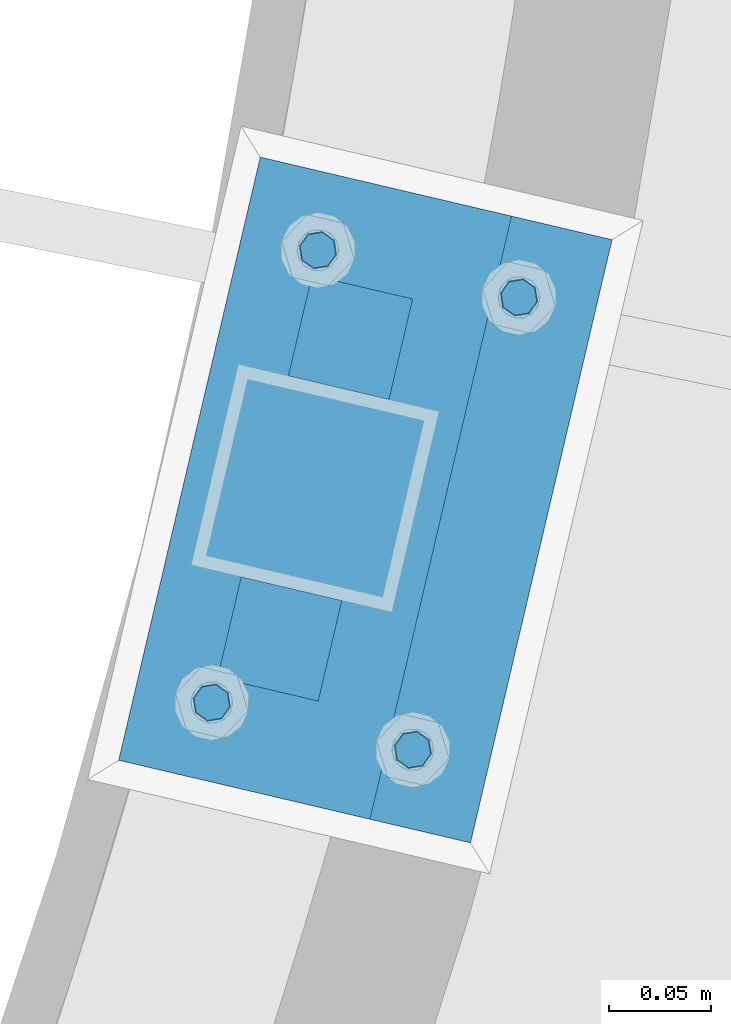
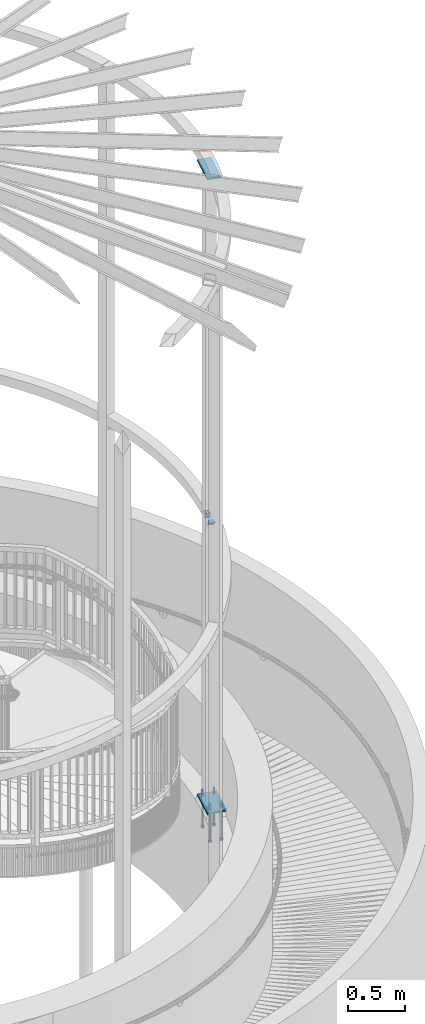
# One storey, part 505 of 975: 9 beams.
"""IFC2X3 building model written with IfcOpenShell, lengths in millimetres."""

from ifc_helpers import new_model, si_unit, frame, origin_with_axes, place, context, subcontext, project, spatial, faceted_brep, material, type_object, element, save


model = new_model("IFC2X3")

# Units and contexts
model_context = context("Model", 3, precision=1e-05, world=origin_with_axes())
body_context = subcontext(model_context, "Body", "Model", "MODEL_VIEW")
ifc_project = project(units=[si_unit("LENGTHUNIT", "METRE", prefix="MILLI"), si_unit("AREAUNIT", "SQUARE_METRE"), si_unit("VOLUMEUNIT", "CUBIC_METRE"), si_unit("MASSUNIT", "GRAM", prefix="KILO"), si_unit("TIMEUNIT", "SECOND"), si_unit("PLANEANGLEUNIT", "RADIAN"), si_unit("SOLIDANGLEUNIT", "STERADIAN"), si_unit("THERMODYNAMICTEMPERATUREUNIT", "DEGREE_CELSIUS"), si_unit("LUMINOUSINTENSITYUNIT", "LUMEN")], contexts=[model_context])

# Site, building, storey
site_placement = place(None, origin_with_axes())
site = spatial("IfcSite", under=ifc_project, at=site_placement, CompositionType="ELEMENT")
building_placement = place(site_placement, origin_with_axes())
building = spatial("IfcBuilding", under=site, at=building_placement, Name="Undefined", CompositionType="ELEMENT")
storey_placement = place(building_placement, origin_with_axes())
storey = spatial("IfcBuildingStorey", under=building, at=storey_placement, Name="Undefined", CompositionType="ELEMENT", Elevation=0.0)

# Beams
ifc_material_1 = material(Name="STEEL/A36")
beam_type_1 = type_object("IfcBeamType", Name="L2X2X1/4", PredefinedType="NOTDEFINED")
for number, where, z_axis, x_axis, name in (
    (1, (37897.6722789189, 2582.8350262257, 4445.0), (-0.228520788077446, -0.973539033329667, 0.0), (0.973539033329667, -0.228520788077446, 0.0), "ANGLE"),
    (2, (37981.954629915, 2719.59351887081, 4445.0), (0.228520788077446, 0.973539033329667, 0.0), (-0.973539033329667, 0.228520788077446, 0.0), "ANGLE"),
):
    element("IfcBeam", number, at=place(storey_placement, frame(where, z_axis=z_axis, x_axis=x_axis)), inside=storey, type_object=beam_type_1, material=ifc_material_1, Name=name, ObjectType="L2X2X1/4", context=body_context, shape_type="Brep", body=[
        faceted_brep([(0.0, 25.3999999999724, -25.4000000000342), (0.0, 25.400000000016, 25.4000000000196), (50.8000000000102, 25.3999999999996, 25.4000000000015), (50.7999999999411, 25.3999999999996, -25.4000000000487), (3.27418092638254e-11, 19.0500000000002, 25.4000000000269), (50.8000000000102, 19.0500000000002, 25.4000000000015), (-2.5465851649642e-11, 19.0500000000002, -19.0500000000211), (50.7999999999483, 19.0500000000002, -19.0500000000429), (-2.5465851649642e-11, -25.3999999999996, -19.0500000000211), (50.7999999999483, -25.3999999999996, -19.0500000000429), (0.0, -25.400000000016, -25.4000000000196), (50.7999999999411, -25.3999999999996, -25.4000000000487)], [[[0, 1, 2, 3]], [[1, 4, 5, 2]], [[4, 6, 7, 5]], [[6, 8, 9, 7]], [[8, 10, 11, 9]], [[10, 0, 3, 11]], [[5, 7, 9, 11, 3, 2]], [[10, 8, 6, 4, 1, 0]]]),
    ])
beam_type_2 = type_object("IfcBeamType", PredefinedType="NOTDEFINED")
beam_1_placement = place(storey_placement, frame((37974.6400225203, 2799.58162122792, 8170.8625), z_axis=(-0.973539033329667, 0.228520788077446, 0.0), x_axis=(-0.228520788077446, -0.973539033329667, 0.0)))
element("IfcBeam", 3, at=beam_1_placement, inside=storey, type_object=beam_type_2, material=ifc_material_1, Name="PLATE", context=body_context, shape_type="Brep", body=[
    faceted_brep([(0.0, 7.9375, -63.5), (0.0, 7.9375, 63.5), (304.799999999529, 7.9375, 63.5), (304.799999999529, 7.9375, -63.5), (0.0, -7.9375, 63.5), (304.799999999529, -7.9375, 63.5), (0.0, -7.9375, -63.5), (304.799999999529, -7.9375, -63.5)], [[[0, 1, 2, 3]], [[1, 4, 5, 2]], [[4, 6, 7, 5]], [[6, 0, 3, 7]], [[5, 7, 3, 2]], [[6, 4, 1, 0]]]),
])
ifc_material_2 = material(Name="STEEL/F1554-36")
beam_type_3 = type_object("IfcBeamType", PredefinedType="NOTDEFINED")
beam_2_placement = place(storey_placement, frame((37888.9656354982, 2545.74318311391, 1371.6), z_axis=(-0.228520788077446, -0.973539033329667, 0.0), x_axis=(0.0, 0.0, -1.0)))
element("IfcBeam", 4, at=beam_2_placement, inside=storey, type_object=beam_type_3, material=ifc_material_2, Name="HEADED_ANCHOR_BOLT", context=body_context, shape_type="Brep", body=[
    faceted_brep([(260.34375, -9.13000011445183, 15.8100004195221), (260.34375, -18.2600002289691, -1.45519152283669e-11), (279.393749999999, -18.2600002289691, -1.45519152283669e-11), (279.393749999999, -9.13000011445183, 15.8100004195221), (260.34375, 9.13000011451732, 15.8100004195403), (279.393749999999, 9.13000011451732, 15.8100004195403), (260.34375, 18.2600002289728, 1.81898940354586e-11), (279.393749999999, 18.2600002289728, 1.81898940354586e-11), (260.34375, 9.13000011445547, -15.8100004195221), (279.393749999999, 9.13000011445547, -15.8100004195221), (260.34375, -9.13000011451732, -15.8100004195367), (279.393749999999, -9.13000011451732, -15.8100004195367), (260.34375, -4.47768005528269, 9.29799844174704), (260.34375, -8.06850066050174, 6.43441456486471), (260.34375, -10.0612557562381, 2.29641597050068), (260.34375, -10.0612557562454, -2.29641597051523), (260.34375, -8.06850066052721, -6.43441456487926), (260.34375, -4.47768005531907, -9.29799844175068), (260.34375, -1.81898940354586e-11, -10.319999694766), (260.34375, 4.47768005528633, -9.2979984417434), (260.34375, 8.06850066050174, -6.43441456486471), (260.34375, 10.0612557562381, -2.29641597050068), (260.34375, 10.0612557562454, 2.29641597051886), (260.34375, 8.06850066052357, 6.4344145648829), (260.34375, 4.47768005532271, 9.29799844175432), (260.34375, 2.18278728425503e-11, 10.3199996947696), (279.393749999999, 2.18278728425503e-11, 10.3199996947696), (279.393749999999, -4.47768005528269, 9.29799844174704), (279.393749999999, -8.06850066050174, 6.43441456486471), (279.393749999999, -10.0612557562381, 2.29641597050068), (279.393749999999, -10.0612557562454, -2.29641597051523), (279.393749999999, -8.06850066052721, -6.43441456487926), (279.393749999999, -4.47768005531907, -9.29799844175068), (279.393749999999, -1.81898940354586e-11, -10.319999694766), (279.393749999999, 4.47768005528633, -9.2979984417434), (279.393749999999, 8.06850066050174, -6.43441456486471), (279.393749999999, 10.0612557562381, -2.29641597050068), (279.393749999999, 10.0612557562454, 2.29641597051886), (279.393749999999, 8.06850066052357, 6.4344145648829), (279.393749999999, 4.47768005532271, 9.29799844175432), (0.0, -6.73519209080223, 6.73519209080186), (0.0, -9.52499999999964, 0.0), (279.400000000001, -9.52499999999782, -3.63797880709171e-12), (279.400000000001, -6.73519209079313, 6.73519209079313), (-9.87109982941227e-13, -1.20792265079217e-13, 9.52499961853027), (279.400000000001, 1.09139364212751e-11, 9.52499999999054), (0.0, 6.73519209080223, 6.73519209080186), (279.400000000001, 6.73519209081132, 6.73519209079677), (0.0, 9.52499999999964, 0.0), (279.400000000001, 9.52500000000146, 3.63797880709171e-12), (0.0, 6.73519209080223, -6.73519209080186), (279.400000000001, 6.73519209079677, -6.73519209079313), (2.95075507493764e-12, -1.20792265079217e-13, -9.52499961853027), (279.400000000001, -1.09139364212751e-11, -9.5249999999869), (-126.99791499542, -6.36396103070001, 6.3639610306418), (-126.99791499542, 1.81898940354586e-11, 8.99999999995271), (-126.99791499542, 6.36396103072184, 6.36396103065272), (-126.99791499542, 9.00000000004366, 1.09139364212751e-11), (-126.99791499542, 6.36396103069637, -6.3639610306418), (-126.99791499542, -1.81898940354586e-11, -8.99999999995271), (-126.99791499542, -6.36396103072184, -6.36396103064908), (-126.99791499542, -9.00000000004002, -7.27595761418343e-12), (0.0149743263646087, 6.36396103067818, -6.36396103067909), (0.0149743263646087, 0.0, -9.0), (0.0149743263646087, -6.36396103067818, -6.36396103067909), (0.0149743263987148, -8.9999995411581, -1.00796984270346e-06), (0.0149743263646087, -6.36396103067818, 6.36396103067909), (0.0149743263646087, 0.0, 9.0), (0.0149743263646087, 6.36396103067818, 6.36396103067909), (0.0149743263987148, 9.0000004588419, -1.00796984270346e-06), (0.0, -6.73519209080223, -6.73519209080186), (279.400000000001, -6.73519209080769, -6.73519209079677)], [[[0, 1, 2, 3]], [[4, 0, 3, 5]], [[6, 4, 5, 7]], [[8, 6, 7, 9]], [[10, 8, 9, 11]], [[0, 4, 6, 8, 10, 1], [12, 13, 14, 15, 16, 17, 18, 19, 20, 21, 22, 23, 24, 25]], [[12, 25, 26, 27]], [[13, 12, 27, 28]], [[14, 13, 28, 29]], [[15, 14, 29, 30]], [[16, 15, 30, 31]], [[17, 16, 31, 32]], [[18, 17, 32, 33]], [[19, 18, 33, 34]], [[20, 19, 34, 35]], [[21, 20, 35, 36]], [[22, 21, 36, 37]], [[23, 22, 37, 38]], [[24, 23, 38, 39]], [[25, 24, 39, 26]], [[9, 7, 5, 3, 2, 11], [38, 37, 36, 35, 34, 33, 32, 31, 30, 29, 28, 27, 26, 39]], [[1, 10, 11, 2]], [[40, 41, 42, 43]], [[44, 40, 43, 45]], [[46, 44, 45, 47]], [[48, 46, 47, 49]], [[50, 48, 49, 51]], [[52, 50, 51, 53]], [[54, 55, 56, 57, 58, 59, 60, 61]], [[59, 58, 62, 63]], [[60, 59, 63, 64]], [[61, 60, 64, 65]], [[54, 61, 65, 66]], [[55, 54, 66, 67]], [[56, 55, 67, 68]], [[57, 56, 68, 69]], [[58, 57, 69, 62]], [[40, 44, 46, 48, 50, 52, 70, 41], [68, 67, 66, 65, 64, 63, 62, 69]], [[41, 70, 71, 42]], [[53, 51, 49, 47, 45, 43, 42, 71]], [[70, 52, 53, 71]]]),
])
beam_3_placement = place(storey_placement, frame((37987.8772026805, 2522.52547698852, 1371.6), z_axis=(0.228520788077446, 0.973539033329667, 0.0), x_axis=(0.0, 0.0, -1.0)))
element("IfcBeam", 5, at=beam_3_placement, inside=storey, type_object=beam_type_3, material=ifc_material_2, Name="HEADED_ANCHOR_BOLT", context=body_context, shape_type="Brep", body=[
    faceted_brep([(260.34375, -9.13000011445183, 15.8100004195221), (260.34375, -18.2600002289691, -1.45519152283669e-11), (279.393749999999, -18.2600002289691, -1.45519152283669e-11), (279.393749999999, -9.13000011445183, 15.8100004195221), (260.34375, 9.13000011451732, 15.8100004195403), (279.393749999999, 9.13000011451732, 15.8100004195403), (260.34375, 18.2600002289728, 1.81898940354586e-11), (279.393749999999, 18.2600002289728, 1.81898940354586e-11), (260.34375, 9.13000011445547, -15.8100004195221), (279.393749999999, 9.13000011445547, -15.8100004195221), (260.34375, -9.13000011451732, -15.8100004195367), (279.393749999999, -9.13000011451732, -15.8100004195367), (260.34375, -4.47768005528269, 9.29799844174704), (260.34375, -8.06850066050174, 6.43441456486471), (260.34375, -10.0612557562381, 2.29641597050068), (260.34375, -10.0612557562454, -2.29641597051523), (260.34375, -8.06850066052721, -6.43441456487926), (260.34375, -4.47768005531907, -9.29799844175068), (260.34375, -1.81898940354586e-11, -10.319999694766), (260.34375, 4.47768005528633, -9.2979984417434), (260.34375, 8.06850066050174, -6.43441456486471), (260.34375, 10.0612557562381, -2.29641597050068), (260.34375, 10.0612557562454, 2.29641597051886), (260.34375, 8.06850066052357, 6.4344145648829), (260.34375, 4.47768005532271, 9.29799844175432), (260.34375, 2.18278728425503e-11, 10.3199996947696), (279.393749999999, 2.18278728425503e-11, 10.3199996947696), (279.393749999999, -4.47768005528269, 9.29799844174704), (279.393749999999, -8.06850066050174, 6.43441456486471), (279.393749999999, -10.0612557562381, 2.29641597050068), (279.393749999999, -10.0612557562454, -2.29641597051523), (279.393749999999, -8.06850066052721, -6.43441456487926), (279.393749999999, -4.47768005531907, -9.29799844175068), (279.393749999999, -1.81898940354586e-11, -10.319999694766), (279.393749999999, 4.47768005528633, -9.2979984417434), (279.393749999999, 8.06850066050174, -6.43441456486471), (279.393749999999, 10.0612557562381, -2.29641597050068), (279.393749999999, 10.0612557562454, 2.29641597051886), (279.393749999999, 8.06850066052357, 6.4344145648829), (279.393749999999, 4.47768005532271, 9.29799844175432), (0.0, -6.73519209080223, 6.73519209080186), (0.0, -9.52499999999964, 0.0), (279.400000000001, -9.52499999999782, -3.63797880709171e-12), (279.400000000001, -6.73519209079313, 6.73519209079313), (-9.87109982941227e-13, -1.20792265079217e-13, 9.52499961853027), (279.400000000001, 1.09139364212751e-11, 9.52499999999054), (0.0, 6.73519209080223, 6.73519209080186), (279.400000000001, 6.73519209081132, 6.73519209079677), (0.0, 9.52499999999964, 0.0), (279.400000000001, 9.52500000000146, 3.63797880709171e-12), (0.0, 6.73519209080223, -6.73519209080186), (279.400000000001, 6.73519209079677, -6.73519209079313), (2.95075507493764e-12, -1.20792265079217e-13, -9.52499961853027), (279.400000000001, -1.09139364212751e-11, -9.5249999999869), (-126.99791499542, -6.36396103070001, 6.3639610306418), (-126.99791499542, 1.81898940354586e-11, 8.99999999995271), (-126.99791499542, 6.36396103072184, 6.36396103065272), (-126.99791499542, 9.00000000004366, 1.09139364212751e-11), (-126.99791499542, 6.36396103069637, -6.3639610306418), (-126.99791499542, -1.81898940354586e-11, -8.99999999995271), (-126.99791499542, -6.36396103072184, -6.36396103064908), (-126.99791499542, -9.00000000004002, -7.27595761418343e-12), (0.0149743263646087, 6.36396103067818, -6.36396103067909), (0.0149743263646087, 0.0, -9.0), (0.0149743263646087, -6.36396103067818, -6.36396103067909), (0.0149743263987148, -8.9999995411581, -1.00796984270346e-06), (0.0149743263646087, -6.36396103067818, 6.36396103067909), (0.0149743263646087, 0.0, 9.0), (0.0149743263646087, 6.36396103067818, 6.36396103067909), (0.0149743263987148, 9.0000004588419, -1.00796984270346e-06), (0.0, -6.73519209080223, -6.73519209080186), (279.400000000001, -6.73519209080769, -6.73519209079677)], [[[0, 1, 2, 3]], [[4, 0, 3, 5]], [[6, 4, 5, 7]], [[8, 6, 7, 9]], [[10, 8, 9, 11]], [[0, 4, 6, 8, 10, 1], [12, 13, 14, 15, 16, 17, 18, 19, 20, 21, 22, 23, 24, 25]], [[12, 25, 26, 27]], [[13, 12, 27, 28]], [[14, 13, 28, 29]], [[15, 14, 29, 30]], [[16, 15, 30, 31]], [[17, 16, 31, 32]], [[18, 17, 32, 33]], [[19, 18, 33, 34]], [[20, 19, 34, 35]], [[21, 20, 35, 36]], [[22, 21, 36, 37]], [[23, 22, 37, 38]], [[24, 23, 38, 39]], [[25, 24, 39, 26]], [[9, 7, 5, 3, 2, 11], [38, 37, 36, 35, 34, 33, 32, 31, 30, 29, 28, 27, 26, 39]], [[1, 10, 11, 2]], [[40, 41, 42, 43]], [[44, 40, 43, 45]], [[46, 44, 45, 47]], [[48, 46, 47, 49]], [[50, 48, 49, 51]], [[52, 50, 51, 53]], [[54, 55, 56, 57, 58, 59, 60, 61]], [[59, 58, 62, 63]], [[60, 59, 63, 64]], [[61, 60, 64, 65]], [[54, 61, 65, 66]], [[55, 54, 66, 67]], [[56, 55, 67, 68]], [[57, 56, 68, 69]], [[58, 57, 69, 62]], [[40, 44, 46, 48, 50, 52, 70, 41], [68, 67, 66, 65, 64, 63, 62, 69]], [[41, 70, 71, 42]], [[53, 51, 49, 47, 45, 43, 42, 71]], [[70, 52, 53, 71]]]),
])
beam_4_placement = place(storey_placement, frame((37941.2054876525, 2768.29420613309, 1371.6), z_axis=(-0.228520788077446, -0.973539033329667, 0.0), x_axis=(0.0, 0.0, -1.0)))
element("IfcBeam", 6, at=beam_4_placement, inside=storey, type_object=beam_type_3, material=ifc_material_2, Name="HEADED_ANCHOR_BOLT", context=body_context, shape_type="Brep", body=[
    faceted_brep([(260.34375, -9.13000011445183, 15.8100004195221), (260.34375, -18.2600002289691, -1.45519152283669e-11), (279.393749999999, -18.2600002289691, -1.45519152283669e-11), (279.393749999999, -9.13000011445183, 15.8100004195221), (260.34375, 9.13000011451732, 15.8100004195403), (279.393749999999, 9.13000011451732, 15.8100004195403), (260.34375, 18.2600002289728, 1.81898940354586e-11), (279.393749999999, 18.2600002289728, 1.81898940354586e-11), (260.34375, 9.13000011445547, -15.8100004195221), (279.393749999999, 9.13000011445547, -15.8100004195221), (260.34375, -9.13000011451732, -15.8100004195367), (279.393749999999, -9.13000011451732, -15.8100004195367), (260.34375, -4.47768005528269, 9.29799844174704), (260.34375, -8.06850066050174, 6.43441456486471), (260.34375, -10.0612557562381, 2.29641597050068), (260.34375, -10.0612557562454, -2.29641597051523), (260.34375, -8.06850066052721, -6.43441456487926), (260.34375, -4.47768005531907, -9.29799844175068), (260.34375, -1.81898940354586e-11, -10.319999694766), (260.34375, 4.47768005528633, -9.2979984417434), (260.34375, 8.06850066050174, -6.43441456486471), (260.34375, 10.0612557562381, -2.29641597050068), (260.34375, 10.0612557562454, 2.29641597051886), (260.34375, 8.06850066052357, 6.4344145648829), (260.34375, 4.47768005532271, 9.29799844175432), (260.34375, 2.18278728425503e-11, 10.3199996947696), (279.393749999999, 2.18278728425503e-11, 10.3199996947696), (279.393749999999, -4.47768005528269, 9.29799844174704), (279.393749999999, -8.06850066050174, 6.43441456486471), (279.393749999999, -10.0612557562381, 2.29641597050068), (279.393749999999, -10.0612557562454, -2.29641597051523), (279.393749999999, -8.06850066052721, -6.43441456487926), (279.393749999999, -4.47768005531907, -9.29799844175068), (279.393749999999, -1.81898940354586e-11, -10.319999694766), (279.393749999999, 4.47768005528633, -9.2979984417434), (279.393749999999, 8.06850066050174, -6.43441456486471), (279.393749999999, 10.0612557562381, -2.29641597050068), (279.393749999999, 10.0612557562454, 2.29641597051886), (279.393749999999, 8.06850066052357, 6.4344145648829), (279.393749999999, 4.47768005532271, 9.29799844175432), (0.0, -6.73519209080223, 6.73519209080186), (0.0, -9.52499999999964, 0.0), (279.400000000001, -9.52499999999782, -3.63797880709171e-12), (279.400000000001, -6.73519209079313, 6.73519209079313), (-9.87109982941227e-13, -1.20792265079217e-13, 9.52499961853027), (279.400000000001, 1.09139364212751e-11, 9.52499999999054), (0.0, 6.73519209080223, 6.73519209080186), (279.400000000001, 6.73519209081132, 6.73519209079677), (0.0, 9.52499999999964, 0.0), (279.400000000001, 9.52500000000146, 3.63797880709171e-12), (0.0, 6.73519209080223, -6.73519209080186), (279.400000000001, 6.73519209079677, -6.73519209079313), (2.95075507493764e-12, -1.20792265079217e-13, -9.52499961853027), (279.400000000001, -1.09139364212751e-11, -9.5249999999869), (-126.99791499542, -6.36396103070001, 6.3639610306418), (-126.99791499542, 1.81898940354586e-11, 8.99999999995271), (-126.99791499542, 6.36396103072184, 6.36396103065272), (-126.99791499542, 9.00000000004366, 1.09139364212751e-11), (-126.99791499542, 6.36396103069637, -6.3639610306418), (-126.99791499542, -1.81898940354586e-11, -8.99999999995271), (-126.99791499542, -6.36396103072184, -6.36396103064908), (-126.99791499542, -9.00000000004002, -7.27595761418343e-12), (0.0149743263646087, 6.36396103067818, -6.36396103067909), (0.0149743263646087, 0.0, -9.0), (0.0149743263646087, -6.36396103067818, -6.36396103067909), (0.0149743263987148, -8.9999995411581, -1.00796984270346e-06), (0.0149743263646087, -6.36396103067818, 6.36396103067909), (0.0149743263646087, 0.0, 9.0), (0.0149743263646087, 6.36396103067818, 6.36396103067909), (0.0149743263987148, 9.0000004588419, -1.00796984270346e-06), (0.0, -6.73519209080223, -6.73519209080186), (279.400000000001, -6.73519209080769, -6.73519209079677)], [[[0, 1, 2, 3]], [[4, 0, 3, 5]], [[6, 4, 5, 7]], [[8, 6, 7, 9]], [[10, 8, 9, 11]], [[0, 4, 6, 8, 10, 1], [12, 13, 14, 15, 16, 17, 18, 19, 20, 21, 22, 23, 24, 25]], [[12, 25, 26, 27]], [[13, 12, 27, 28]], [[14, 13, 28, 29]], [[15, 14, 29, 30]], [[16, 15, 30, 31]], [[17, 16, 31, 32]], [[18, 17, 32, 33]], [[19, 18, 33, 34]], [[20, 19, 34, 35]], [[21, 20, 35, 36]], [[22, 21, 36, 37]], [[23, 22, 37, 38]], [[24, 23, 38, 39]], [[25, 24, 39, 26]], [[9, 7, 5, 3, 2, 11], [38, 37, 36, 35, 34, 33, 32, 31, 30, 29, 28, 27, 26, 39]], [[1, 10, 11, 2]], [[40, 41, 42, 43]], [[44, 40, 43, 45]], [[46, 44, 45, 47]], [[48, 46, 47, 49]], [[50, 48, 49, 51]], [[52, 50, 51, 53]], [[54, 55, 56, 57, 58, 59, 60, 61]], [[59, 58, 62, 63]], [[60, 59, 63, 64]], [[61, 60, 64, 65]], [[54, 61, 65, 66]], [[55, 54, 66, 67]], [[56, 55, 67, 68]], [[57, 56, 68, 69]], [[58, 57, 69, 62]], [[40, 44, 46, 48, 50, 52, 70, 41], [68, 67, 66, 65, 64, 63, 62, 69]], [[41, 70, 71, 42]], [[53, 51, 49, 47, 45, 43, 42, 71]], [[70, 52, 53, 71]]]),
])
beam_5_placement = place(storey_placement, frame((38040.1170548344, 2745.07650000615, 1371.6), z_axis=(0.228520788077446, 0.973539033329667, 0.0), x_axis=(0.0, 0.0, -1.0)))
element("IfcBeam", 7, at=beam_5_placement, inside=storey, type_object=beam_type_3, material=ifc_material_2, Name="HEADED_ANCHOR_BOLT", context=body_context, shape_type="Brep", body=[
    faceted_brep([(260.34375, -9.13000011445183, 15.8100004195221), (260.34375, -18.2600002289691, -1.45519152283669e-11), (279.393749999999, -18.2600002289691, -1.45519152283669e-11), (279.393749999999, -9.13000011445183, 15.8100004195221), (260.34375, 9.13000011451732, 15.8100004195403), (279.393749999999, 9.13000011451732, 15.8100004195403), (260.34375, 18.2600002289728, 1.81898940354586e-11), (279.393749999999, 18.2600002289728, 1.81898940354586e-11), (260.34375, 9.13000011445547, -15.8100004195221), (279.393749999999, 9.13000011445547, -15.8100004195221), (260.34375, -9.13000011451732, -15.8100004195367), (279.393749999999, -9.13000011451732, -15.8100004195367), (260.34375, -4.47768005528269, 9.29799844174704), (260.34375, -8.06850066050174, 6.43441456486471), (260.34375, -10.0612557562381, 2.29641597050068), (260.34375, -10.0612557562454, -2.29641597051523), (260.34375, -8.06850066052721, -6.43441456487926), (260.34375, -4.47768005531907, -9.29799844175068), (260.34375, -1.81898940354586e-11, -10.319999694766), (260.34375, 4.47768005528633, -9.2979984417434), (260.34375, 8.06850066050174, -6.43441456486471), (260.34375, 10.0612557562381, -2.29641597050068), (260.34375, 10.0612557562454, 2.29641597051886), (260.34375, 8.06850066052357, 6.4344145648829), (260.34375, 4.47768005532271, 9.29799844175432), (260.34375, 2.18278728425503e-11, 10.3199996947696), (279.393749999999, 2.18278728425503e-11, 10.3199996947696), (279.393749999999, -4.47768005528269, 9.29799844174704), (279.393749999999, -8.06850066050174, 6.43441456486471), (279.393749999999, -10.0612557562381, 2.29641597050068), (279.393749999999, -10.0612557562454, -2.29641597051523), (279.393749999999, -8.06850066052721, -6.43441456487926), (279.393749999999, -4.47768005531907, -9.29799844175068), (279.393749999999, -1.81898940354586e-11, -10.319999694766), (279.393749999999, 4.47768005528633, -9.2979984417434), (279.393749999999, 8.06850066050174, -6.43441456486471), (279.393749999999, 10.0612557562381, -2.29641597050068), (279.393749999999, 10.0612557562454, 2.29641597051886), (279.393749999999, 8.06850066052357, 6.4344145648829), (279.393749999999, 4.47768005532271, 9.29799844175432), (0.0, -6.73519209080223, 6.73519209080186), (0.0, -9.52499999999964, 0.0), (279.400000000001, -9.52499999999782, -3.63797880709171e-12), (279.400000000001, -6.73519209079313, 6.73519209079313), (-9.87109982941227e-13, -1.20792265079217e-13, 9.52499961853027), (279.400000000001, 1.09139364212751e-11, 9.52499999999054), (0.0, 6.73519209080223, 6.73519209080186), (279.400000000001, 6.73519209081132, 6.73519209079677), (0.0, 9.52499999999964, 0.0), (279.400000000001, 9.52500000000146, 3.63797880709171e-12), (0.0, 6.73519209080223, -6.73519209080186), (279.400000000001, 6.73519209079677, -6.73519209079313), (2.95075507493764e-12, -1.20792265079217e-13, -9.52499961853027), (279.400000000001, -1.09139364212751e-11, -9.5249999999869), (-126.99791499542, -6.36396103070001, 6.3639610306418), (-126.99791499542, 1.81898940354586e-11, 8.99999999995271), (-126.99791499542, 6.36396103072184, 6.36396103065272), (-126.99791499542, 9.00000000004366, 1.09139364212751e-11), (-126.99791499542, 6.36396103069637, -6.3639610306418), (-126.99791499542, -1.81898940354586e-11, -8.99999999995271), (-126.99791499542, -6.36396103072184, -6.36396103064908), (-126.99791499542, -9.00000000004002, -7.27595761418343e-12), (0.0149743263646087, 6.36396103067818, -6.36396103067909), (0.0149743263646087, 0.0, -9.0), (0.0149743263646087, -6.36396103067818, -6.36396103067909), (0.0149743263987148, -8.9999995411581, -1.00796984270346e-06), (0.0149743263646087, -6.36396103067818, 6.36396103067909), (0.0149743263646087, 0.0, 9.0), (0.0149743263646087, 6.36396103067818, 6.36396103067909), (0.0149743263987148, 9.0000004588419, -1.00796984270346e-06), (0.0, -6.73519209080223, -6.73519209080186), (279.400000000001, -6.73519209080769, -6.73519209079677)], [[[0, 1, 2, 3]], [[4, 0, 3, 5]], [[6, 4, 5, 7]], [[8, 6, 7, 9]], [[10, 8, 9, 11]], [[0, 4, 6, 8, 10, 1], [12, 13, 14, 15, 16, 17, 18, 19, 20, 21, 22, 23, 24, 25]], [[12, 25, 26, 27]], [[13, 12, 27, 28]], [[14, 13, 28, 29]], [[15, 14, 29, 30]], [[16, 15, 30, 31]], [[17, 16, 31, 32]], [[18, 17, 32, 33]], [[19, 18, 33, 34]], [[20, 19, 34, 35]], [[21, 20, 35, 36]], [[22, 21, 36, 37]], [[23, 22, 37, 38]], [[24, 23, 38, 39]], [[25, 24, 39, 26]], [[9, 7, 5, 3, 2, 11], [38, 37, 36, 35, 34, 33, 32, 31, 30, 29, 28, 27, 26, 39]], [[1, 10, 11, 2]], [[40, 41, 42, 43]], [[44, 40, 43, 45]], [[46, 44, 45, 47]], [[48, 46, 47, 49]], [[50, 48, 49, 51]], [[52, 50, 51, 53]], [[54, 55, 56, 57, 58, 59, 60, 61]], [[59, 58, 62, 63]], [[60, 59, 63, 64]], [[61, 60, 64, 65]], [[54, 61, 65, 66]], [[55, 54, 66, 67]], [[56, 55, 67, 68]], [[57, 56, 68, 69]], [[58, 57, 69, 62]], [[40, 44, 46, 48, 50, 52, 70, 41], [68, 67, 66, 65, 64, 63, 62, 69]], [[41, 70, 71, 42]], [[53, 51, 49, 47, 45, 43, 42, 71]], [[70, 52, 53, 71]]]),
])
beam_type_4 = type_object("IfcBeamType", PredefinedType="NOTDEFINED")
beam_6_placement = place(storey_placement, frame((37999.3679139666, 2793.77719321048, 1419.225), z_axis=(0.973539033329667, -0.228520788077446, 0.0), x_axis=(-0.228520788077446, -0.973539033329667, 0.0)))
element("IfcBeam", 8, at=beam_6_placement, inside=storey, type_object=beam_type_4, material=ifc_material_1, Name="PLATE", context=body_context, shape_type="Brep", body=[
    faceted_brep([(0.0, 9.52499999999964, -88.9000000000015), (0.0, 9.52499999999964, 88.9000000000015), (304.800000000429, 9.52500000000009, 88.9000000003653), (304.800000000414, 9.52500000000009, -88.8999999996704), (0.0, -9.52499999999964, 88.9000000000015), (304.800000000429, -9.52500000000009, 88.9000000003653), (0.0, -9.52499999999964, -88.9000000000015), (304.800000000414, -9.52500000000009, -88.8999999996704)], [[[0, 1, 2, 3]], [[1, 4, 5, 2]], [[4, 6, 7, 5]], [[6, 0, 3, 7]], [[5, 7, 3, 2]], [[6, 4, 1, 0]]]),
])
beam_type_5 = type_object("IfcBeamType", PredefinedType="NOTDEFINED")
beam_7_placement = place(storey_placement, frame((37999.3679139667, 2793.7771932105, 1411.2875), z_axis=(0.973539033329667, -0.228520788077446, 0.0), x_axis=(-0.228520788077446, -0.973539033329667, 0.0)))
element("IfcBeam", 9, at=beam_7_placement, inside=storey, type_object=beam_type_5, material=ifc_material_1, Name="TEMPLATE", context=body_context, shape_type="Brep", body=[
    faceted_brep([(-1.09139364212751e-11, 1.58750000000009, -88.900000000016), (3.63797880709171e-12, 1.58750000000009, 88.9000000000196), (304.800000000418, 1.58750000000009, 88.9000000003762), (304.800000000399, 1.58750000000009, -88.8999999996631), (3.63797880709171e-12, -1.58750000000009, 88.9000000000196), (304.800000000418, -1.58750000000009, 88.9000000003762), (-1.09139364212751e-11, -1.58750000000009, -88.900000000016), (304.800000000399, -1.58750000000009, -88.8999999996631)], [[[0, 1, 2, 3]], [[1, 4, 5, 2]], [[4, 6, 7, 5]], [[6, 0, 3, 7]], [[5, 7, 3, 2]], [[6, 4, 1, 0]]]),
])

save(model, "model.ifc")
